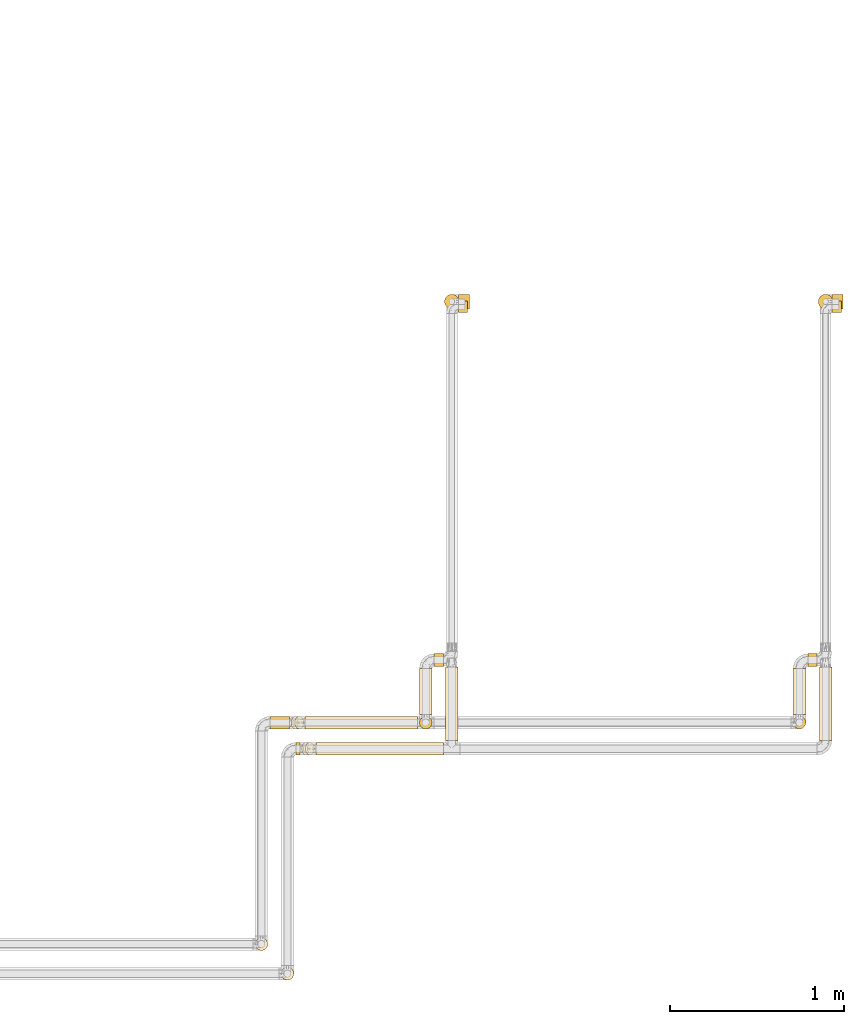
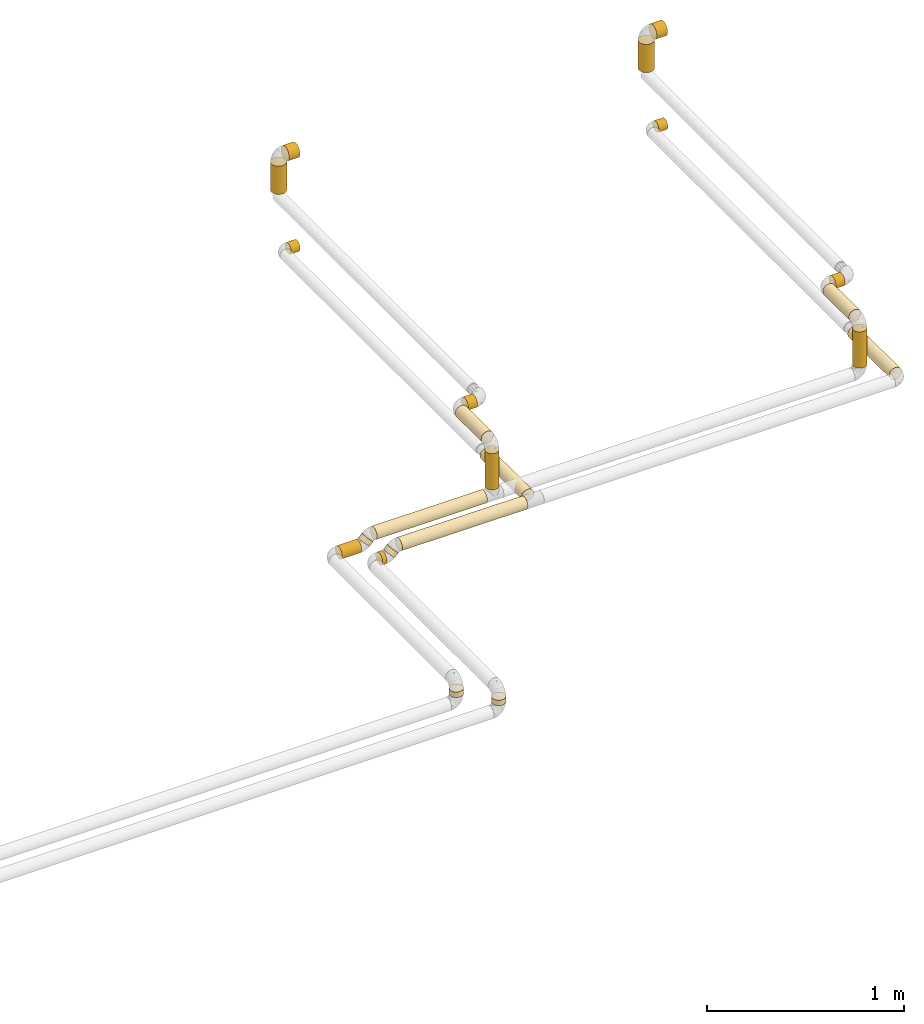
# One storey, part 3 of 39: 22 coverings.
"""IFC2X3 building model written with IfcOpenShell, lengths in millimetres."""

from ifc_helpers import new_model, entity, si_unit, converted_unit, derived_unit, direction, frame, origin, origin_2d_with_axis, place, context, subcontext, project, spatial, circle, extrude, element, save


model = new_model("IFC2X3")

# Units and contexts
model_context = context("Model", 3, precision=0.01, world=origin(), true_north=direction((6.12303176911189e-17, 1.0)))
body_context = subcontext(model_context, "Body", "Model", "MODEL_VIEW")
ifc_project = project(units=[si_unit("LENGTHUNIT", "METRE", prefix="MILLI"), si_unit("AREAUNIT", "SQUARE_METRE"), si_unit("VOLUMEUNIT", "CUBIC_METRE"), converted_unit("PLANEANGLEUNIT", "DEGREE", entity("IfcRatioMeasure", 0.0174532925199433), si_unit("PLANEANGLEUNIT", "RADIAN"), dimensions=[0, 0, 0, 0, 0, 0, 0]), si_unit("MASSUNIT", "GRAM", prefix="KILO"), derived_unit("MASSDENSITYUNIT", [(si_unit("MASSUNIT", "GRAM", prefix="KILO"), 1), (si_unit("LENGTHUNIT", "METRE"), -3)]), derived_unit("MOMENTOFINERTIAUNIT", [(si_unit("LENGTHUNIT", "METRE"), 4)]), si_unit("TIMEUNIT", "SECOND"), si_unit("FREQUENCYUNIT", "HERTZ"), si_unit("THERMODYNAMICTEMPERATUREUNIT", "DEGREE_CELSIUS"), derived_unit("THERMALTRANSMITTANCEUNIT", [(si_unit("MASSUNIT", "GRAM", prefix="KILO"), 1), (si_unit("THERMODYNAMICTEMPERATUREUNIT", "KELVIN"), -1), (si_unit("TIMEUNIT", "SECOND"), -3)]), derived_unit("VOLUMETRICFLOWRATEUNIT", [(si_unit("LENGTHUNIT", "METRE"), 3), (si_unit("TIMEUNIT", "SECOND"), -1)]), derived_unit("MASSFLOWRATEUNIT", [(si_unit("MASSUNIT", "GRAM", prefix="KILO"), 1), (si_unit("TIMEUNIT", "SECOND"), -1)]), derived_unit("ROTATIONALFREQUENCYUNIT", [(si_unit("TIMEUNIT", "SECOND"), -1)]), si_unit("ELECTRICCURRENTUNIT", "AMPERE"), si_unit("ELECTRICVOLTAGEUNIT", "VOLT"), si_unit("POWERUNIT", "WATT"), si_unit("FORCEUNIT", "NEWTON", prefix="KILO"), si_unit("ILLUMINANCEUNIT", "LUX"), si_unit("LUMINOUSFLUXUNIT", "LUMEN"), si_unit("LUMINOUSINTENSITYUNIT", "CANDELA"), derived_unit("USERDEFINED", [(si_unit("MASSUNIT", "GRAM", prefix="KILO"), -1), (si_unit("LENGTHUNIT", "METRE"), -2), (si_unit("TIMEUNIT", "SECOND"), 3), (si_unit("LUMINOUSFLUXUNIT", "LUMEN"), 1)]), derived_unit("LINEARVELOCITYUNIT", [(si_unit("LENGTHUNIT", "METRE"), 1), (si_unit("TIMEUNIT", "SECOND"), -1)]), si_unit("PRESSUREUNIT", "PASCAL"), derived_unit("USERDEFINED", [(si_unit("LENGTHUNIT", "METRE"), -2), (si_unit("MASSUNIT", "GRAM", prefix="KILO"), 1), (si_unit("TIMEUNIT", "SECOND"), -2)]), derived_unit("LINEARFORCEUNIT", [(si_unit("MASSUNIT", "GRAM", prefix="KILO"), 1), (si_unit("LENGTHUNIT", "METRE"), 1), (si_unit("TIMEUNIT", "SECOND"), -2), (si_unit("LENGTHUNIT", "METRE"), -1)]), derived_unit("PLANARFORCEUNIT", [(si_unit("MASSUNIT", "GRAM", prefix="KILO"), 1), (si_unit("LENGTHUNIT", "METRE"), 1), (si_unit("TIMEUNIT", "SECOND"), -2), (si_unit("LENGTHUNIT", "METRE"), -2)])], contexts=[model_context])

# Site, building, storey
site_placement = place(None, origin())
site = spatial("IfcSite", under=ifc_project, at=site_placement, CompositionType="ELEMENT")
building_placement = place(site_placement, origin())
building = spatial("IfcBuilding", under=site, at=building_placement, CompositionType="ELEMENT")
storey_placement = place(building_placement, frame((0.0, 0.0, 24000.0)))
storey = spatial("IfcBuildingStorey", under=building, at=storey_placement, Name="07", CompositionType="ELEMENT", Elevation=24000.0)

# Coverings
covering_1_placement = place(storey_placement, frame((71721.67, 5254.01, 3438.0)))
element("IfcCovering", 1, at=covering_1_placement, inside=storey, Name=":ADSK_", ObjectType=":ADSK_", PredefinedType="INSULATION", context=body_context, shape_type="SweptSolid", body=[
    extrude(circle(Radius=41.75, at=origin_2d_with_axis()), frame((43.35, 43.35, 0.0), z_axis=(0.0, 0.0, 1.0), x_axis=(0.0, -1.0, 0.0)), (0.0, 0.0, 1.0), 174.000000000017),
])
covering_2_placement = place(storey_placement, frame((71803.01, 5253.91, 3606.55)))
element("IfcCovering", 2, at=covering_2_placement, inside=storey, Name=":ADSK_", ObjectType=":ADSK_", PredefinedType="INSULATION", context=body_context, shape_type="SweptSolid", body=[
    extrude(circle(Radius=41.85, at=origin_2d_with_axis()), frame((0.0, 43.45, 43.45), z_axis=(1.0, 0.0, 0.0), x_axis=(0.0, 0.0, 1.0)), (0.0, 0.0, 1.0), 63.000000000003),
])
covering_3_placement = place(storey_placement, frame((69571.67, 5254.01, 3438.0)))
element("IfcCovering", 3, at=covering_3_placement, inside=storey, Name=":ADSK_", ObjectType=":ADSK_", PredefinedType="INSULATION", context=body_context, shape_type="SweptSolid", body=[
    extrude(circle(Radius=41.75, at=origin_2d_with_axis()), frame((43.35, 43.35, 0.0), z_axis=(0.0, 0.0, 1.0), x_axis=(0.0, -1.0, 0.0)), (0.0, 0.0, 1.0), 174.000000000017),
])
covering_4_placement = place(storey_placement, frame((69653.01, 5253.91, 3606.55)))
element("IfcCovering", 4, at=covering_4_placement, inside=storey, Name=":ADSK_", ObjectType=":ADSK_", PredefinedType="INSULATION", context=body_context, shape_type="SweptSolid", body=[
    extrude(circle(Radius=41.85, at=origin_2d_with_axis()), frame((0.0, 43.45, 43.45), z_axis=(1.0, 0.0, 0.0), x_axis=(0.0, 0.0, 1.0)), (0.0, 0.0, 1.0), 63.000000000003),
])
covering_5_placement = place(storey_placement, frame((68832.77, 2687.61, 3042.21)))
element("IfcCovering", 5, at=covering_5_placement, inside=storey, Name=":ADSK_", ObjectType=":ADSK_", PredefinedType="INSULATION", context=body_context, shape_type="SweptSolid", body=[
    extrude(circle(Radius=36.15, at=origin_2d_with_axis()), frame((0.0, 37.75, 37.75), z_axis=(1.0, 0.0, 1.50942445489092e-05), x_axis=(0.0, -1.0, 0.0)), (0.0, 0.0, 1.0), 734.245453428102),
])
covering_6_placement = place(storey_placement, frame((68718.08, 2687.61, 2992.21)))
element("IfcCovering", 6, at=covering_6_placement, inside=storey, Name=":ADSK_", ObjectType=":ADSK_", PredefinedType="INSULATION", context=body_context, shape_type="SweptSolid", body=[
    extrude(circle(Radius=36.15, at=origin_2d_with_axis()), frame((0.0, 37.75, 37.75), z_axis=(1.0, 0.0, 5.50119725918368e-06), x_axis=(0.0, 1.0, 0.0)), (0.0, 0.0, 1.0), 24.9274987801464),
])
covering_7_placement = place(storey_placement, frame((68749.79, 2687.61, 3016.86)))
element("IfcCovering", 7, at=covering_7_placement, inside=storey, Name=":ADSK_", ObjectType=":ADSK_", PredefinedType="INSULATION", context=body_context, shape_type="SweptSolid", body=[
    extrude(circle(Radius=36.15, at=origin_2d_with_axis()), frame((27.16, 37.75, 27.16), z_axis=(0.707101350399028, 0.0, 0.707112211932357), x_axis=(0.0, 1.0, 0.0)), (0.0, 0.0, 1.0), 30.9461083930041),
])
covering_8_placement = place(storey_placement, frame((71803.01, 5233.91, 3046.55)))
element("IfcCovering", 8, at=covering_8_placement, inside=storey, Name=":ADSK_", ObjectType=":ADSK_", PredefinedType="INSULATION", context=body_context, shape_type="SweptSolid", body=[
    extrude(circle(Radius=31.85, at=origin_2d_with_axis()), frame((0.0, 33.45, 33.45), z_axis=(1.0, 0.0, 0.0), x_axis=(0.0, 1.0, 0.0)), (0.0, 0.0, 1.0), 52.9999999999966),
])
covering_9_placement = place(storey_placement, frame((71727.27, 2773.35, 3042.25)))
element("IfcCovering", 9, at=covering_9_placement, inside=storey, Name=":ADSK_", ObjectType=":ADSK_", PredefinedType="INSULATION", context=body_context, shape_type="SweptSolid", body=[
    extrude(circle(Radius=36.15, at=origin_2d_with_axis()), frame((37.75, 0.0, 37.75), z_axis=(0.0, 1.0, -3.90443941309916e-06), x_axis=(1.0, 0.0, 0.0)), (0.0, 0.0, 1.0), 422.000000003597),
])
covering_10_placement = place(storey_placement, frame((69653.01, 5233.91, 3046.55)))
element("IfcCovering", 10, at=covering_10_placement, inside=storey, Name=":ADSK_", ObjectType=":ADSK_", PredefinedType="INSULATION", context=body_context, shape_type="SweptSolid", body=[
    extrude(circle(Radius=31.85, at=origin_2d_with_axis()), frame((0.0, 33.45, 33.45), z_axis=(1.0, 0.0, 0.0), x_axis=(0.0, 1.0, 0.0)), (0.0, 0.0, 1.0), 52.9999999999966),
])
covering_11_placement = place(storey_placement, frame((69577.27, 2773.35, 3042.22)))
element("IfcCovering", 11, at=covering_11_placement, inside=storey, Name=":ADSK_", ObjectType=":ADSK_", PredefinedType="INSULATION", context=body_context, shape_type="SweptSolid", body=[
    extrude(circle(Radius=36.15, at=origin_2d_with_axis()), frame((37.75, 0.0, 37.75), z_axis=(0.0, 0.999999996652785, 8.18194919635431e-05), x_axis=(1.0, 0.0, 0.0)), (0.0, 0.0, 1.0), 422.00000141289),
])
covering_12_placement = place(storey_placement, frame((68632.33, 1393.43, 2948.42)))
element("IfcCovering", 12, at=covering_12_placement, inside=storey, Name=":ADSK_", ObjectType=":ADSK_", PredefinedType="INSULATION", context=body_context, shape_type="SweptSolid", body=[
    extrude(circle(Radius=36.15, at=origin_2d_with_axis()), frame((37.75, 37.75, 0.0), z_axis=(0.0, 0.0, 1.0), x_axis=(0.0, -1.0, 0.0)), (0.0, 0.0, 1.0), 33.5307095401164),
])
covering_13_placement = place(storey_placement, frame((68771.89, 2837.61, 3042.25)))
element("IfcCovering", 13, at=covering_13_placement, inside=storey, Name=":ADSK_", ObjectType=":ADSK_", PredefinedType="INSULATION", context=body_context, shape_type="SweptSolid", body=[
    extrude(circle(Radius=36.15, at=origin_2d_with_axis()), frame((0.0, 37.75, 37.75), z_axis=(1.0, 0.0, 0.0), x_axis=(0.0, -1.0, 0.0)), (0.0, 0.0, 1.0), 645.120882763224),
])
covering_14_placement = place(storey_placement, frame((68568.07, 2837.61, 2992.23)))
element("IfcCovering", 14, at=covering_14_placement, inside=storey, Name=":ADSK_", ObjectType=":ADSK_", PredefinedType="INSULATION", context=body_context, shape_type="SweptSolid", body=[
    extrude(circle(Radius=36.15, at=origin_2d_with_axis()), frame((0.0, 37.75, 37.76), z_axis=(0.999999991447934, -2.11779484169515e-05, -0.000129056682198737), x_axis=(-2.11779485933175e-05, -1.0, 0.0)), (0.0, 0.0, 1.0), 114.004835076223),
])
covering_15_placement = place(storey_placement, frame((68688.88, 2837.61, 3016.87)))
element("IfcCovering", 15, at=covering_15_placement, inside=storey, Name=":ADSK_", ObjectType=":ADSK_", PredefinedType="INSULATION", context=body_context, shape_type="SweptSolid", body=[
    extrude(circle(Radius=36.15, at=origin_2d_with_axis()), frame((49.08, 37.75, 49.08), z_axis=(-0.707185586519227, 1.49767398856591e-05, -0.707027966911602), x_axis=(2.11779484307877e-05, 1.0, 0.0)), (0.0, 0.0, 1.0), 31.0019998521835),
])
covering_16_placement = place(storey_placement, frame((71577.27, 2837.61, 3128.0)))
element("IfcCovering", 16, at=covering_16_placement, inside=storey, Name=":ADSK_", ObjectType=":ADSK_", PredefinedType="INSULATION", context=body_context, shape_type="SweptSolid", body=[
    extrude(circle(Radius=36.15, at=origin_2d_with_axis()), frame((37.75, 37.75, 0.0), z_axis=(0.0, 0.0, 1.0), x_axis=(0.0, 1.0, 0.0)), (0.0, 0.0, 1.0), 224.000000000018),
])
covering_17_placement = place(storey_placement, frame((71577.27, 2923.35, 3362.25)))
element("IfcCovering", 17, at=covering_17_placement, inside=storey, Name=":ADSK_", ObjectType=":ADSK_", PredefinedType="INSULATION", context=body_context, shape_type="SweptSolid", body=[
    extrude(circle(Radius=36.15, at=origin_2d_with_axis()), frame((37.75, 0.0, 37.75), z_axis=(0.0, 1.0, 0.0), x_axis=(-1.0, 0.0, 0.0)), (0.0, 0.0, 1.0), 264.00000000001),
])
covering_18_placement = place(storey_placement, frame((71663.01, 3197.61, 3362.25)))
element("IfcCovering", 18, at=covering_18_placement, inside=storey, Name=":ADSK_", ObjectType=":ADSK_", PredefinedType="INSULATION", context=body_context, shape_type="SweptSolid", body=[
    extrude(circle(Radius=36.15, at=origin_2d_with_axis()), frame((0.0, 37.75, 37.75), z_axis=(1.0, 0.0, 0.0), x_axis=(0.0, -1.0, 0.0)), (0.0, 0.0, 1.0), 54.0000000000051),
])
covering_19_placement = place(storey_placement, frame((69427.27, 2923.35, 3362.25)))
element("IfcCovering", 19, at=covering_19_placement, inside=storey, Name=":ADSK_", ObjectType=":ADSK_", PredefinedType="INSULATION", context=body_context, shape_type="SweptSolid", body=[
    extrude(circle(Radius=36.15, at=origin_2d_with_axis()), frame((37.75, 0.0, 37.75), z_axis=(0.0, 1.0, 0.0), x_axis=(1.0, 0.0, 0.0)), (0.0, 0.0, 1.0), 264.000000000017),
])
covering_20_placement = place(storey_placement, frame((69513.01, 3197.61, 3362.25)))
element("IfcCovering", 20, at=covering_20_placement, inside=storey, Name=":ADSK_", ObjectType=":ADSK_", PredefinedType="INSULATION", context=body_context, shape_type="SweptSolid", body=[
    extrude(circle(Radius=36.15, at=origin_2d_with_axis()), frame((0.0, 37.75, 37.75), z_axis=(1.0, 0.0, 0.0), x_axis=(0.0, -1.0, 0.0)), (0.0, 0.0, 1.0), 54.0000000000051),
])
covering_21_placement = place(storey_placement, frame((69427.27, 2837.61, 3128.0)))
element("IfcCovering", 21, at=covering_21_placement, inside=storey, Name=":ADSK_", ObjectType=":ADSK_", PredefinedType="INSULATION", context=body_context, shape_type="SweptSolid", body=[
    extrude(circle(Radius=36.15, at=origin_2d_with_axis()), frame((37.75, 37.75, 0.0), z_axis=(0.0, 0.0, 1.0), x_axis=(-1.0, 0.0, 0.0)), (0.0, 0.0, 1.0), 224.000000000031),
])
covering_22_placement = place(storey_placement, frame((68482.33, 1563.43, 2948.04)))
element("IfcCovering", 22, at=covering_22_placement, inside=storey, Name=":ADSK_", ObjectType=":ADSK_", PredefinedType="INSULATION", context=body_context, shape_type="SweptSolid", body=[
    extrude(circle(Radius=36.15, at=origin_2d_with_axis()), frame((37.75, 37.75, 0.0), z_axis=(0.0, 0.0, 1.0), x_axis=(0.0, -1.0, 0.0)), (0.0, 0.0, 1.0), 33.8601090380695),
])

save(model, "model.ifc")
